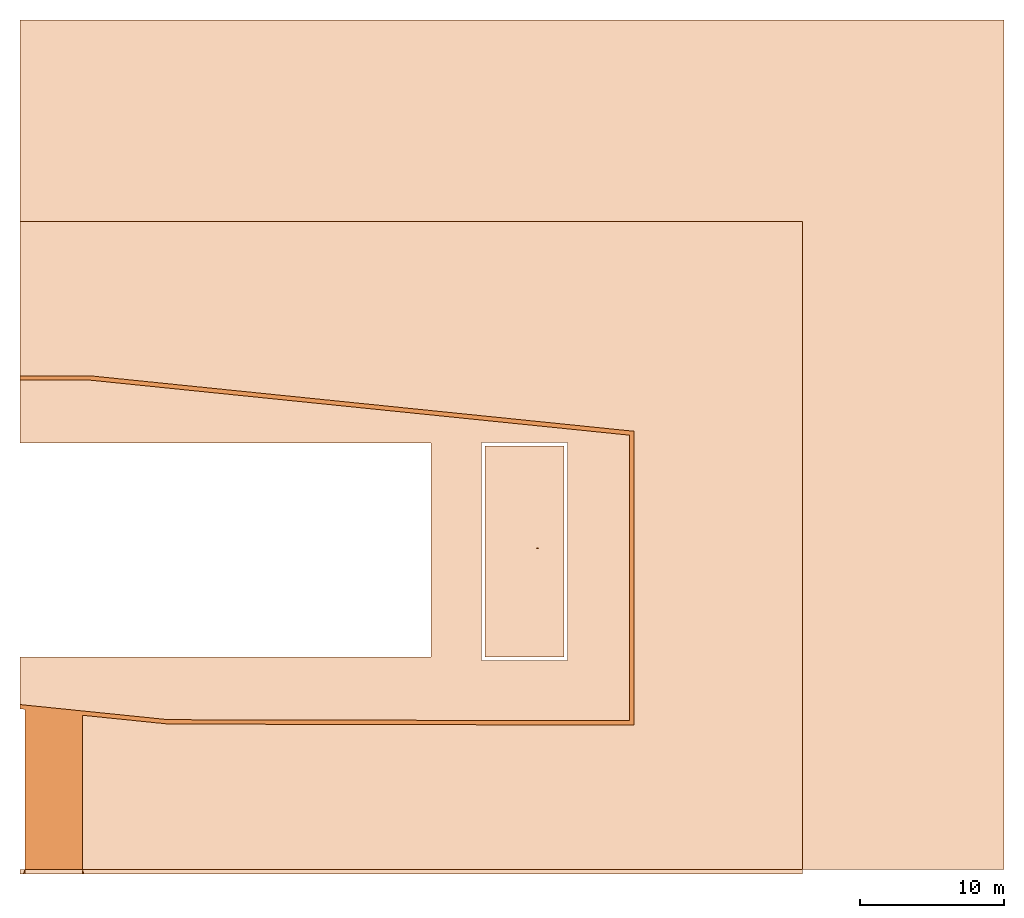
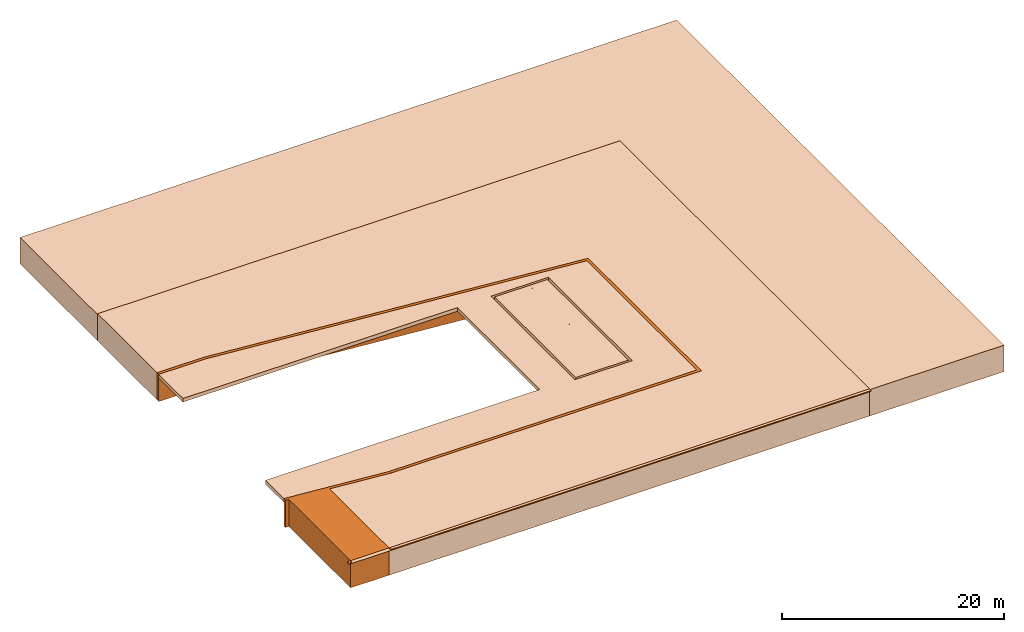
# Not in any storey: 6 geographic elements.
"""IFC4 model written with IfcOpenShell, lengths in metres."""

from ifc_helpers import new_model, entity, si_unit, converted_unit, derived_unit, direction, frame, origin_with_axes, place, context, subcontext, project, spatial, polygons, material, type_object, element, save


model = new_model("IFC4")

# Units and contexts
model_context = context("Model", 3, precision=1e-05, world=origin_with_axes(), true_north=direction((0.0, 1.0)))
body_context = subcontext(model_context, "Body", "Model", "MODEL_VIEW")
ifc_project = project(units=[si_unit("LENGTHUNIT", "METRE"), si_unit("AREAUNIT", "SQUARE_METRE"), si_unit("VOLUMEUNIT", "CUBIC_METRE"), converted_unit("PLANEANGLEUNIT", "DEGREE", entity("IfcPlaneAngleMeasure", 0.0174532925199433), si_unit("PLANEANGLEUNIT", "RADIAN"), dimensions=[0, 0, 0, 0, 0, 0, 0]), converted_unit("TIMEUNIT", "Year", entity("IfcTimeMeasure", 31557600.0), si_unit("TIMEUNIT", "SECOND"), dimensions=[0, 0, 1, 0, 0, 0, 0]), si_unit("MASSUNIT", "GRAM", prefix="KILO"), si_unit("THERMODYNAMICTEMPERATUREUNIT", "DEGREE_CELSIUS"), si_unit("LUMINOUSINTENSITYUNIT", "LUMEN"), si_unit("ENERGYUNIT", "JOULE", prefix="MEGA"), derived_unit("THERMALCONDUCTANCEUNIT", [(si_unit("POWERUNIT", "WATT"), 1), (si_unit("LENGTHUNIT", "METRE"), -1), (si_unit("THERMODYNAMICTEMPERATUREUNIT", "KELVIN"), -1)]), derived_unit("SPECIFICHEATCAPACITYUNIT", [(si_unit("ENERGYUNIT", "JOULE"), 1), (si_unit("MASSUNIT", "GRAM", prefix="KILO"), -1), (si_unit("THERMODYNAMICTEMPERATUREUNIT", "KELVIN"), -1)]), derived_unit("MASSDENSITYUNIT", [(si_unit("MASSUNIT", "GRAM", prefix="KILO"), 1), (si_unit("VOLUMEUNIT", "CUBIC_METRE"), -1)])], contexts=[model_context])

# Site
site_placement = place(None, origin_with_axes())
site = spatial("IfcSite", under=ifc_project, at=site_placement, CompositionType="ELEMENT")

# Geographic elements
ifc_material_1 = material(Name="Wasser")
geographic_element_type_1 = type_object("IfcGeographicElementType", Name="Wasser 350", PredefinedType="USERDEFINED")
geographic_element_1_placement = place(site_placement, frame((56.196, 0.0, 0.0), z_axis=(0.0, 0.0, 1.0), x_axis=(1.0, 0.0, 0.0)))
element("IfcGeographicElement", 1, at=geographic_element_1_placement, inside=site, type_object=geographic_element_type_1, material=ifc_material_1, Name="Decke-001", ObjectType="WATER", PredefinedType="USERDEFINED", context=body_context, shape_type="Tessellation", body=[
    polygons([(5.479999999999997, 14.62299994546756, 0.0), (0.0, 14.62299994546756, 0.0), (0.0, 0.0, 0.0), (5.479999999999997, 0.0, 0.0), (3.623899999999999, 0.7331999454675557, 0.0), (3.567, 0.7331999454675557, 0.0), (3.567, 0.742999945467556, 0.0), (3.687000000000005, 0.742999945467556, 0.0), (3.687000000000005, 0.7331999454675557, 0.0), (3.630100000000006, 0.7331999454675557, 0.0), (3.630100000000006, 0.512799945467556, 0.0), (3.687000000000005, 0.512799945467556, 0.0), (3.687000000000005, 0.5029999454675558, 0.0), (3.567, 0.5029999454675558, 0.0), (3.567, 0.512799945467556, 0.0), (3.623899999999999, 0.512799945467556, 0.0), (3.623899999999999, 7.533199945467555, 0.0), (3.567, 7.533199945467555, 0.0), (3.567, 7.542999945467555, 0.0), (3.687000000000005, 7.542999945467555, 0.0), (3.687000000000005, 7.533199945467555, 0.0), (3.630100000000006, 7.533199945467555, 0.0), (3.630100000000006, 7.312799945467555, 0.0), (3.687000000000005, 7.312799945467555, 0.0), (3.687000000000005, 7.302999945467555, 0.0), (3.567, 7.302999945467555, 0.0), (3.567, 7.312799945467555, 0.0), (3.623899999999999, 7.312799945467555, 0.0), (3.623899999999999, 14.33319994546756, 0.0), (3.567, 14.33319994546756, 0.0), (3.567, 14.34299994546756, 0.0), (3.687000000000005, 14.34299994546756, 0.0), (3.687000000000005, 14.33319994546756, 0.0), (3.630100000000006, 14.33319994546756, 0.0), (3.630100000000006, 14.11279994546756, 0.0), (3.687000000000005, 14.11279994546756, 0.0), (3.687000000000005, 14.10299994546756, 0.0), (3.567, 14.10299994546756, 0.0), (3.567, 14.11279994546756, 0.0), (3.623899999999999, 14.11279994546756, 0.0), (5.479999999999997, 14.62299994546756, -0.3500000000000001), (0.0, 14.62299994546756, -0.3500000000000001), (0.0, 0.0, -0.3500000000000001), (5.479999999999997, 0.0, -0.3500000000000001), (3.567, 0.7331999454675557, -0.1499999999999999), (3.623899999999999, 0.7331999454675557, -0.1499999999999999), (3.567, 0.742999945467556, -0.1499999999999999), (3.687000000000005, 0.742999945467556, -0.1499999999999999), (3.687000000000005, 0.7331999454675557, -0.1499999999999999), (3.630100000000006, 0.7331999454675557, -0.1499999999999999), (3.630100000000006, 0.512799945467556, -0.1499999999999999), (3.687000000000005, 0.512799945467556, -0.1499999999999999), (3.687000000000005, 0.5029999454675558, -0.1499999999999999), (3.567, 0.5029999454675558, -0.1499999999999999), (3.567, 0.512799945467556, -0.1499999999999999), (3.623899999999999, 0.512799945467556, -0.1499999999999999), (3.567, 7.533199945467555, -0.1499999999999999), (3.623899999999999, 7.533199945467555, -0.1499999999999999), (3.567, 7.542999945467555, -0.1499999999999999), (3.687000000000005, 7.542999945467555, -0.1499999999999999), (3.687000000000005, 7.533199945467555, -0.1499999999999999), (3.630100000000006, 7.533199945467555, -0.1499999999999999), (3.630100000000006, 7.312799945467555, -0.1499999999999999), (3.687000000000005, 7.312799945467555, -0.1499999999999999), (3.687000000000005, 7.302999945467555, -0.1499999999999999), (3.567, 7.302999945467555, -0.1499999999999999), (3.567, 7.312799945467555, -0.1499999999999999), (3.623899999999999, 7.312799945467555, -0.1499999999999999), (3.567, 14.33319994546756, -0.1499999999999999), (3.623899999999999, 14.33319994546756, -0.1499999999999999), (3.567, 14.34299994546756, -0.1499999999999999), (3.687000000000005, 14.34299994546756, -0.1499999999999999), (3.687000000000005, 14.33319994546756, -0.1499999999999999), (3.630100000000006, 14.33319994546756, -0.1499999999999999), (3.630100000000006, 14.11279994546756, -0.1499999999999999), (3.687000000000005, 14.11279994546756, -0.1499999999999999), (3.687000000000005, 14.10299994546756, -0.1499999999999999), (3.567, 14.10299994546756, -0.1499999999999999), (3.567, 14.11279994546756, -0.1499999999999999), (3.623899999999999, 14.11279994546756, -0.1499999999999999)], [[[1, 2, 3, 4], [5, 6, 7, 8, 9, 10, 11, 12, 13, 14, 15, 16], [17, 18, 19, 20, 21, 22, 23, 24, 25, 26, 27, 28], [29, 30, 31, 32, 33, 34, 35, 36, 37, 38, 39, 40]], [[2, 1, 41, 42]], [[3, 2, 42, 43]], [[4, 3, 43, 44]], [[1, 4, 44, 41]], [[45, 6, 5, 46]], [[47, 7, 6, 45]], [[48, 8, 7, 47]], [[49, 9, 8, 48]], [[50, 10, 9, 49]], [[51, 11, 10, 50]], [[52, 12, 11, 51]], [[53, 13, 12, 52]], [[54, 14, 13, 53]], [[55, 15, 14, 54]], [[56, 16, 15, 55]], [[46, 5, 16, 56]], [[57, 18, 17, 58]], [[59, 19, 18, 57]], [[60, 20, 19, 59]], [[61, 21, 20, 60]], [[62, 22, 21, 61]], [[63, 23, 22, 62]], [[64, 24, 23, 63]], [[65, 25, 24, 64]], [[66, 26, 25, 65]], [[67, 27, 26, 66]], [[68, 28, 27, 67]], [[58, 17, 28, 68]], [[69, 30, 29, 70]], [[71, 31, 30, 69]], [[72, 32, 31, 71]], [[73, 33, 32, 72]], [[74, 34, 33, 73]], [[75, 35, 34, 74]], [[76, 36, 35, 75]], [[77, 37, 36, 76]], [[78, 38, 37, 77]], [[79, 39, 38, 78]], [[80, 40, 39, 79]], [[70, 29, 40, 80]], [[41, 44, 43, 42]], [[53, 52, 51, 50, 49, 48, 47, 45, 46, 56, 55, 54]], [[65, 64, 63, 62, 61, 60, 59, 57, 58, 68, 67, 66]], [[77, 76, 75, 74, 73, 72, 71, 69, 70, 80, 79, 78]]], closed=True),
])
ifc_material_2 = material(Name="Pf")
geographic_element_type_2 = type_object("IfcGeographicElementType", Name="Pf", PredefinedType="TERRAIN")
geographic_element_2_placement = place(site_placement, frame((23.88799999999999, -14.77700005453244, -3.0), z_axis=(0.0, 0.0, 1.0), x_axis=(1.0, 0.0, 0.0)))
element("IfcGeographicElement", 2, at=geographic_element_2_placement, inside=site, type_object=geographic_element_type_2, material=ifc_material_2, PredefinedType="TERRAIN", context=body_context, shape_type="Tessellation", body=[
    polygons([(0.3350000000000044, 11.12365748335244, 3.0), (0.335000000000008, 0.0, 3.0), (4.335000000000008, 0.0, 3.0), (4.335000000000008, 10.71574689074824, 3.0), (10.30272615194914, 10.10865611975514, 3.0), (42.63500000000001, 10.03169175359411, 3.0), (42.63499999999999, 30.43901840308458, 3.0), (4.843559724307486, 34.29134472114438, 3.0), (0.0, 34.29134472114438, 3.0), (0.0, 33.99134472114439, 3.0), (4.843559724307486, 33.99134472114439, 3.0), (42.33500000000001, 30.16805581603359, 3.0), (42.33500000000001, 10.33738852951559, 3.0), (10.30344027569251, 10.4086552697994, 3.0), (4.335000000000008, 11.01730277224454, 3.0), (0.0, 11.45937587697936, 3.0), (0.0, 11.15781999548304, 3.0), (0.335000000000008, 0.0, 0.0), (0.3350000000000044, 11.12365748335244, 0.0), (4.335000000000008, 0.0, 0.0), (4.335000000000008, 10.71574689074824, 0.0), (10.30272615194914, 10.10865611975514, 0.0), (42.63500000000001, 10.03169175359411, 0.0), (42.63499999999999, 30.43901840308458, 0.0), (4.843559724307486, 34.29134472114438, 0.0), (0.0, 34.29134472114438, 0.0), (0.0, 33.99134472114439, 0.0), (4.843559724307486, 33.99134472114439, 0.0), (42.33500000000001, 30.16805581603359, 0.0), (42.33500000000001, 10.33738852951559, 0.0), (10.30344027569251, 10.4086552697994, 0.0), (4.335000000000008, 11.01730277224454, 0.0), (0.0, 11.45937587697936, 0.0), (0.0, 11.15781999548304, 0.0)], [[[1, 2, 3, 4, 5, 6, 7, 8, 9, 10, 11, 12, 13, 14, 15, 16, 17]], [[18, 2, 1, 19]], [[20, 3, 2, 18]], [[21, 4, 3, 20]], [[22, 5, 4, 21]], [[23, 6, 5, 22]], [[24, 7, 6, 23]], [[25, 8, 7, 24]], [[26, 9, 8, 25]], [[27, 10, 9, 26]], [[28, 11, 10, 27]], [[29, 12, 11, 28]], [[30, 13, 12, 29]], [[31, 14, 13, 30]], [[32, 15, 14, 31]], [[33, 16, 15, 32]], [[34, 17, 16, 33]], [[19, 1, 17, 34]], [[34, 33, 32, 31, 30, 29, 28, 27, 26, 25, 24, 23, 22, 21, 20, 18, 19]]], closed=True),
])
ifc_material_3 = material(Name="Gras")
geographic_element_type_3 = type_object("IfcGeographicElementType", Name="Gras", PredefinedType="TERRAIN")
geographic_element_3_placement = place(site_placement, frame((23.888, -14.77700005453244, -3.0), z_axis=(0.0, 0.0, 1.0), x_axis=(1.0, 0.0, 0.0)))
element("IfcGeographicElement", 3, at=geographic_element_3_placement, inside=site, type_object=geographic_element_type_3, material=ifc_material_3, PredefinedType="TERRAIN", context=body_context, shape_type="Tessellation", body=[
    polygons([(54.335, 45.0, 3.0), (0.0, 45.0, 3.0), (0.0, 34.29134472114438, 3.0), (4.843559724307482, 34.29134472114438, 3.0), (4.843559724307482, 34.2929006026407, 3.0), (42.63499999999998, 30.43901840308458, 3.0), (42.635, 10.03169175359411, 3.0), (10.30272615194913, 10.10865611975514, 3.0), (10.30272262048614, 10.10717257309322, 3.0), (4.335000000000001, 10.71574689074824, 3.0), (4.335000000000001, 0.0, 3.0), (54.335, 0.0, 3.0), (0.0, 45.0, 0.0), (54.335, 45.0, 0.0), (0.0, 34.29134472114438, 0.0), (4.843559724307482, 34.29134472114438, 0.0), (4.843559724307482, 34.2929006026407, 0.0), (42.63499999999998, 30.43901840308458, 0.0), (42.635, 10.03169175359411, 0.0), (10.30272615194913, 10.10865611975514, 0.0), (10.30272262048614, 10.10717257309322, 0.0), (4.335000000000001, 10.71574689074824, 0.0), (4.335000000000001, 0.0, 0.0), (54.335, 0.0, 0.0)], [[[1, 2, 3, 4, 5, 6, 7, 8, 9, 10, 11, 12]], [[13, 2, 1, 14]], [[15, 3, 2, 13]], [[16, 4, 3, 15]], [[17, 5, 4, 16]], [[18, 6, 5, 17]], [[19, 7, 6, 18]], [[20, 8, 7, 19]], [[21, 9, 8, 20]], [[22, 10, 9, 21]], [[23, 11, 10, 22]], [[24, 12, 11, 23]], [[14, 1, 12, 24]], [[14, 24, 23, 22, 21, 20, 19, 18, 17, 16, 15, 13]]], closed=True),
])
geographic_element_4_placement = place(site_placement, frame((23.888, -14.77700005453244, -3.0), z_axis=(0.0, 0.0, 1.0), x_axis=(1.0, 0.0, 0.0)))
element("IfcGeographicElement", 4, at=geographic_element_4_placement, inside=site, type_object=geographic_element_type_3, material=ifc_material_3, PredefinedType="TERRAIN", context=body_context, shape_type="Tessellation", body=[
    polygons([(68.33500000000001, 59.0, 2.9), (0.0, 59.0, 2.9), (0.0, 45.0, 2.9), (54.335, 45.0, 2.9), (54.335, 0.0, 2.9), (68.33500000000001, 0.0, 2.9), (0.0, 59.0, 0.0), (68.33500000000001, 59.0, 0.0), (0.0, 45.0, 0.0), (54.335, 45.0, 0.0), (54.335, 0.0, 0.0), (68.33500000000001, 0.0, 0.0)], [[[1, 2, 3, 4, 5, 6]], [[7, 2, 1, 8]], [[9, 3, 2, 7]], [[10, 4, 3, 9]], [[11, 5, 4, 10]], [[12, 6, 5, 11]], [[8, 1, 6, 12]], [[8, 12, 11, 10, 9, 7]]], closed=True),
])
ifc_material_4 = material(Name="Umgebung")
geographic_element_type_4 = type_object("IfcGeographicElementType", Name="Umgebung", PredefinedType="USERDEFINED")
geographic_element_5_placement = place(site_placement, frame((23.88799999999999, -4.43961152501685, -0.4), z_axis=(0.0, 0.0, 1.0), x_axis=(1.0, 0.0, 0.0)))
element("IfcGeographicElement", 5, at=geographic_element_5_placement, inside=site, type_object=geographic_element_type_4, material=ifc_material_4, ObjectType="PAVEMENT", PredefinedType="USERDEFINED", context=body_context, shape_type="Tessellation", body=[
    polygons([(42.33500000000001, 0.0, 0.4), (42.33500000000001, 19.830667286518, 0.4), (4.843559724307486, 23.65395619162879, 0.4), (0.0, 23.65395619162879, 0.4), (0.0, 19.28561140689563, 0.4), (28.558, 19.28561140689563, 0.4), (28.558, 4.439611525016851, 0.4), (0.0, 4.439611525016851, 0.4), (0.0, 1.121987347463764, 0.4), (10.30344027569251, 0.07126674028380453, 0.4), (38.038, 4.18961152501685, 0.4), (32.05800000000001, 4.18961152501685, 0.4), (32.05800000000001, 19.31261147048441, 0.4), (38.038, 19.31261147048441, 0.4), (42.33500000000001, 19.830667286518, 0.0), (42.33500000000001, 0.0, 0.0), (4.843559724307486, 23.65395619162879, 0.0), (0.0, 23.65395619162879, 0.0), (0.0, 19.28561140689563, 0.0), (28.558, 19.28561140689563, 0.0), (28.558, 4.439611525016851, 0.0), (0.0, 4.439611525016851, 0.0), (0.0, 1.121987347463764, 0.0), (10.30344027569251, 0.07126674028380453, 0.0), (32.05800000000001, 4.18961152501685, 0.0), (38.038, 4.18961152501685, 0.0), (32.05800000000001, 19.31261147048441, 0.0), (38.038, 19.31261147048441, 0.0)], [[[1, 2, 3, 4, 5, 6, 7, 8, 9, 10], [11, 12, 13, 14]], [[15, 2, 1, 16]], [[17, 3, 2, 15]], [[18, 4, 3, 17]], [[19, 5, 4, 18]], [[20, 6, 5, 19]], [[21, 7, 6, 20]], [[22, 8, 7, 21]], [[23, 9, 8, 22]], [[24, 10, 9, 23]], [[16, 1, 10, 24]], [[25, 12, 11, 26]], [[27, 13, 12, 25]], [[28, 14, 13, 27]], [[26, 11, 14, 28]], [[24, 23, 22, 21, 20, 19, 18, 17, 15, 16], [25, 26, 28, 27]]], closed=True),
])
geographic_element_type_5 = type_object("IfcGeographicElementType", Name="Pf", PredefinedType="USERDEFINED")
geographic_element_6_placement = place(site_placement, frame((23.88799999999999, -15.07700005453244, -0.1000000000000001), z_axis=(0.0, 0.0, 1.0), x_axis=(1.0, 0.0, 0.0)))
element("IfcGeographicElement", 6, at=geographic_element_6_placement, inside=site, type_object=geographic_element_type_5, material=ifc_material_2, ObjectType="PAVEMENT", PredefinedType="USERDEFINED", context=body_context, shape_type="Tessellation", body=[
    polygons([(4.335000000000012, 0.3000000000000007, 0.1000000000000001), (0.3350000000000115, 0.3000000000000007, 0.1000000000000001), (0.3350000000000115, 0.0, 0.0), (4.335000000000012, 0.0, 0.0), (0.0, 0.3000000000000007, 0.0), (0.0, 0.3000000000000007, 0.1000000000000001), (54.33500000000001, 0.3000000000000007, 0.1000000000000001), (54.33500000000001, 0.3000000000000007, 0.0), (0.2350000000000101, 0.0, 0.1000000000000001), (0.0, 0.0, 0.0), (54.33500000000001, 0.0, 0.0), (4.435000000000013, 0.0, 0.1000000000000001), (0.0, 0.0, 0.1000000000000001), (54.33500000000001, 0.0, 0.1000000000000001)], [[[1, 2, 3, 4]], [[5, 6, 2, 1, 7, 8]], [[9, 3, 2]], [[10, 5, 8, 11, 4, 3]], [[12, 1, 4]], [[10, 13, 6, 5]], [[13, 9, 2, 6]], [[12, 14, 7, 1]], [[8, 7, 14, 11]], [[3, 9, 13, 10]], [[11, 14, 12, 4]]], closed=True),
])

save(model, "model.ifc")
